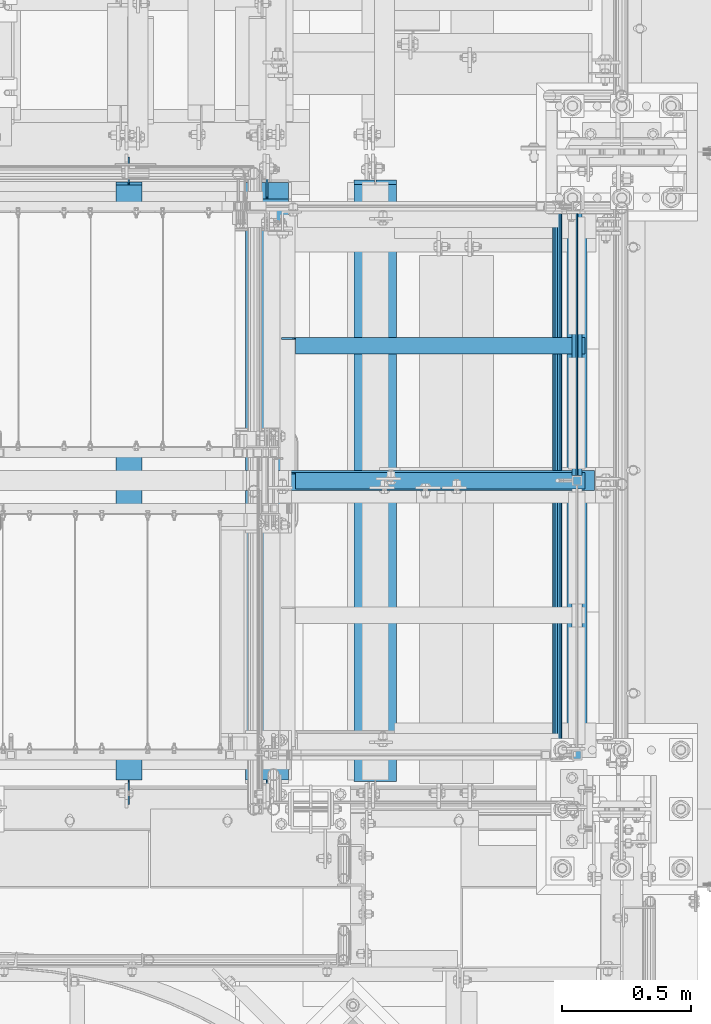
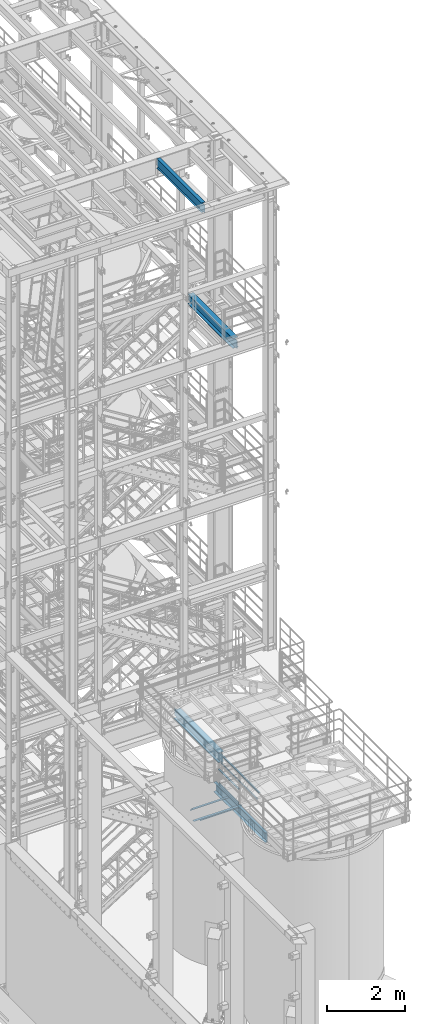
# One storey, part 985 of 1876: 11 beams, 6 elements without a shape of their own.
"""IFC2X3 building model written with IfcOpenShell, lengths in millimetres."""

from ifc_helpers import new_model, si_unit, frame, origin_with_axes, place, context, subcontext, project, spatial, faceted_brep, material, type_object, element, aggregate, save


model = new_model("IFC2X3")

# Units and contexts
model_context = context("Model", 3, precision=1e-05, world=origin_with_axes())
body_context = subcontext(model_context, "Body", "Model", "MODEL_VIEW")
ifc_project = project(units=[si_unit("LENGTHUNIT", "METRE", prefix="MILLI"), si_unit("AREAUNIT", "SQUARE_METRE"), si_unit("VOLUMEUNIT", "CUBIC_METRE"), si_unit("MASSUNIT", "GRAM", prefix="KILO"), si_unit("TIMEUNIT", "SECOND"), si_unit("PLANEANGLEUNIT", "RADIAN"), si_unit("SOLIDANGLEUNIT", "STERADIAN"), si_unit("THERMODYNAMICTEMPERATUREUNIT", "DEGREE_CELSIUS"), si_unit("LUMINOUSINTENSITYUNIT", "LUMEN")], contexts=[model_context])

# Site, building, storey
site_placement = place(None, origin_with_axes())
site = spatial("IfcSite", under=ifc_project, at=site_placement, CompositionType="ELEMENT")
building_placement = place(site_placement, origin_with_axes())
building = spatial("IfcBuilding", under=site, at=building_placement, Name="Undefined", CompositionType="ELEMENT")
storey_placement = place(building_placement, origin_with_axes())
storey = spatial("IfcBuildingStorey", under=building, at=storey_placement, Name="Undefined", CompositionType="ELEMENT", Elevation=0.0)

# Assembly, beams
assembly_1_placement = place(storey_placement, origin_with_axes())
assembly_1 = element("IfcElementAssembly", 1, at=assembly_1_placement, inside=storey, Name="STRINGER", AssemblyPlace="NOTDEFINED", PredefinedType="RIGID_FRAME")
ifc_material_1 = material(Name="STEEL/A36")
beam_type_1 = type_object("IfcBeamType", Name="L2-1/2X2-1/2X1/4", PredefinedType="NOTDEFINED")
beam_1_placement = place(assembly_1_placement, frame((6299.20000020042, -5842.00000113825, 2266.27941839083), z_axis=(0.0, -1.0, 0.0), x_axis=(1.0, 0.0, 0.0)))
beam_1 = element("IfcBeam", 2, at=beam_1_placement, type_object=beam_type_1, material=ifc_material_1, Name="STRINGER", ObjectType="L2-1/2X2-1/2X1/4", context=body_context, shape_type="Brep", body=[
    faceted_brep([(1177.92499923677, 25.4000000000001, -25.3999999999996), (1177.92499923677, 25.4000000000001, 31.75), (58.737000000001, 25.4000000000001, 31.75), (58.737000000001, 25.4000000000001, -25.3999999999996), (1177.92499923677, 31.75, 31.75), (58.737000000001, 31.75, 31.75), (46.0370001907359, 6.34999909337057, -25.3999999999996), (46.0370001907359, 6.34999909337057, -31.75), (6.34999514770607, 6.34999909337057, -31.75), (6.34999514770607, 6.34999909337057, -25.3999999999996), (50.8970797087813, 7.31672901595857, -25.3999999999996), (50.8970797087813, 7.31672901595857, -31.75), (55.017256176935, 10.0697429164366, -25.3999999999996), (55.017256176935, 10.0697429164366, -31.75), (57.7702700774134, 14.1899193845902, -25.3999999999996), (57.7702700774134, 14.1899193845902, -31.75), (58.737000000001, 19.0499989026357, -25.3999999999996), (58.737000000001, 19.0499989026357, -31.75), (58.737000000001, 31.75, -31.75), (1177.92499923677, 31.75, -31.75), (1177.92499923677, -31.75, -25.3999999999996), (1177.92499923677, -31.75, -31.75), (6.34999999999854, -31.75, -25.3999999999996), (6.34999999999854, -31.75, -31.75), (6.34999514770607, -19.0499986178111, -31.75), (6.34999514770607, -19.0499986178111, -25.3999999999996)], [[[0, 1, 2, 3]], [[1, 4, 5, 2]], [[6, 7, 8, 9]], [[10, 11, 7, 6]], [[12, 13, 11, 10]], [[14, 15, 13, 12]], [[16, 17, 15, 14]], [[2, 5, 18, 17, 16, 3]], [[4, 19, 18, 5]], [[1, 0, 20, 21, 19, 4]], [[21, 20, 22, 23]], [[8, 7, 11, 13, 15, 17, 18, 19, 21, 23, 24]], [[9, 8, 24, 25]], [[20, 0, 3, 16, 14, 12, 10, 6, 9, 25, 22]], [[24, 23, 22, 25]]]),
])
beam_2_placement = place(assembly_1_placement, frame((6299.20000038161, -5321.30000113914, 2266.27941824714), z_axis=(0.0, -1.0, 0.0), x_axis=(1.0, 0.0, 0.0)))
beam_2 = element("IfcBeam", 3, at=beam_2_placement, type_object=beam_type_1, material=ifc_material_1, Name="STRINGER", ObjectType="L2-1/2X2-1/2X1/4", context=body_context, shape_type="Brep", body=[
    faceted_brep([(1177.92499923677, 25.4000000000001, -25.3999999999996), (1177.92499923677, 25.4000000000001, 31.75), (58.737000000001, 25.4000000000001, 31.75), (58.737000000001, 25.4000000000001, -25.3999999999996), (1177.92499923677, 31.75, 31.75), (58.737000000001, 31.75, 31.75), (46.0370001907359, 6.34999909337057, -25.3999999999996), (46.0370001907359, 6.34999909337057, -31.75), (6.34999514770607, 6.34999909337057, -31.75), (6.34999514770607, 6.34999909337057, -25.3999999999996), (50.8970797087813, 7.31672901595857, -25.3999999999996), (50.8970797087813, 7.31672901595857, -31.75), (55.017256176935, 10.0697429164366, -25.3999999999996), (55.017256176935, 10.0697429164366, -31.75), (57.7702700774134, 14.1899193845902, -25.3999999999996), (57.7702700774134, 14.1899193845902, -31.75), (58.737000000001, 19.0499989026357, -25.3999999999996), (58.737000000001, 19.0499989026357, -31.75), (58.737000000001, 31.75, -31.75), (1177.92499923677, 31.75, -31.75), (1177.92499923677, -31.75, -25.3999999999996), (1177.92499923677, -31.75, -31.75), (6.34999999999854, -31.75, -25.3999999999996), (6.34999999999854, -31.75, -31.75), (6.34999514770607, -19.0499986178111, -31.75), (6.34999514770607, -19.0499986178111, -25.3999999999996)], [[[0, 1, 2, 3]], [[1, 4, 5, 2]], [[6, 7, 8, 9]], [[10, 11, 7, 6]], [[12, 13, 11, 10]], [[14, 15, 13, 12]], [[16, 17, 15, 14]], [[2, 5, 18, 17, 16, 3]], [[4, 19, 18, 5]], [[1, 0, 20, 21, 19, 4]], [[21, 20, 22, 23]], [[8, 7, 11, 13, 15, 17, 18, 19, 21, 23, 24]], [[9, 8, 24, 25]], [[20, 0, 3, 16, 14, 12, 10, 6, 9, 25, 22]], [[24, 23, 22, 25]]]),
])

# Assembly, beam
assembly_2_placement = place(storey_placement, origin_with_axes())
assembly_2 = element("IfcElementAssembly", 4, at=assembly_2_placement, inside=storey, Name="RAIL", AssemblyPlace="NOTDEFINED", PredefinedType="RIGID_FRAME")
beam_type_2 = type_object("IfcBeamType", PredefinedType="NOTDEFINED")
beam_3_placement = place(assembly_2_placement, frame((7446.96249979876, -4800.6000004494, 2393.27941810157), z_axis=(0.0, 0.0, 1.0), x_axis=(0.0, -1.0, 0.0)))
beam_3 = element("IfcBeam", 5, at=beam_3_placement, type_object=beam_type_2, material=ifc_material_1, Name="PLATE", context=body_context, shape_type="Brep", body=[
    faceted_brep([(0.0, 3.17500000000018, -50.8000000000002), (0.0, 3.17500000000018, 50.8000000000002), (1022.35000148923, 3.17500000000018, 50.8000000000002), (1022.35000148923, 3.17500000000018, -50.8000000000002), (0.0, -3.17500000000018, 50.8000000000002), (1022.35000148923, -3.17500000000018, 50.8000000000002), (0.0, -3.17500000000018, -50.8000000000002), (1022.35000148923, -3.17500000000018, -50.8000000000002)], [[[0, 1, 2, 3]], [[1, 4, 5, 2]], [[4, 6, 7, 5]], [[6, 0, 3, 7]], [[5, 7, 3, 2]], [[6, 4, 1, 0]]]),
])

assembly_3_placement = place(storey_placement, origin_with_axes())
assembly_3 = element("IfcElementAssembly", 6, at=assembly_3_placement, inside=storey, Name="BEAM", AssemblyPlace="NOTDEFINED", PredefinedType="RIGID_FRAME")
ifc_material_2 = material(Name="STEEL/A992")
beam_type_3 = type_object("IfcBeamType", Name="W12X16", PredefinedType="NOTDEFINED")
beam_4_placement = place(assembly_3_placement, frame((5715.0, -7112.0, 22402.8), z_axis=(0.0, 0.0, 1.0), x_axis=(0.0, 1.0, 0.0)))
beam_4 = element("IfcBeam", 7, at=beam_4_placement, type_object=beam_type_3, material=ifc_material_2, Name="BEAM", ObjectType="W12X16", context=body_context, shape_type="Brep", body=[
    faceted_brep([(17.4625000000005, -3.17500000000018, -126.999999999999), (17.4625000000005, 3.17500000000018, -126.999999999999), (100.012500190734, 3.17500000000018, -126.999999999999), (100.012500190734, -3.17500000000018, -126.999999999999), (104.87257970878, 3.17500000000018, -127.966729922587), (104.87257970878, -3.17500000000018, -127.966729922587), (108.992756176934, 3.17500000000018, -130.719743823065), (108.992756176934, -3.17500000000018, -130.719743823065), (111.745770077412, 3.17500000000018, -134.839920291219), (111.745770077412, -3.17500000000018, -134.839920291219), (112.7125, -3.17500000000018, -139.699999809264), (112.7125, 3.17500000000018, -139.699999809264), (112.712500000001, 3.17500000000018, -146.049999999999), (112.7125, 50.8000000000002, -146.05), (112.7125, 50.8000000000002, -152.4), (112.7125, -50.8000000000002, -152.4), (112.7125, -50.8000000000002, -146.05), (112.712500000001, -3.17500000000018, -146.049999999999), (2412.20625, 50.8000000000002, 146.049999999999), (2412.20625, 3.17500000000018, 146.049999999999), (112.712500000001, 3.17500000000018, 146.05), (112.712500000001, 50.8000000000002, 146.049999999999), (100.012500190735, -3.17500000000018, 114.299999999996), (100.012500190735, 3.17500000000018, 114.299999999996), (17.4624999999996, 3.17500000000018, 114.299999999996), (17.4624999999996, -3.17500000000018, 114.299999999996), (104.872579708781, -3.17500000000018, 115.266729922583), (104.872579708781, 3.17500000000018, 115.266729922583), (108.992756176935, -3.17500000000018, 118.019743823061), (108.992756176935, 3.17500000000018, 118.019743823061), (111.745770077413, -3.17500000000018, 122.139920291214), (111.745770077413, 3.17500000000018, 122.139920291214), (112.712500000001, -3.17500000000018, 126.999999809261), (112.712500000001, 3.17500000000018, 126.999999809261), (2412.20625, -50.8000000000002, 152.400000000001), (2412.20625, 50.8000000000002, 152.400000000001), (112.712500000001, 50.8000000000002, 152.400000000001), (112.712500000001, -50.8000000000002, 152.400000000001), (2412.20625, -50.8000000000002, 146.049999999999), (112.712500000001, -50.8000000000002, 146.049999999999), (2412.20625, -3.17500000000018, 146.049999999999), (112.712500000001, -3.17500000000018, 146.05), (2412.20625, -3.17500000000018, 126.999999809268), (2412.20625, 3.17500000000018, 126.999999809268), (2413.17297992259, -3.17500000000018, 122.139920291222), (2413.17297992259, 3.17500000000018, 122.139920291222), (2415.92599382307, -3.17500000000018, 118.019743823068), (2415.92599382307, 3.17500000000018, 118.019743823068), (2420.04617029122, -3.17500000000018, 115.26672992259), (2420.04617029122, 3.17500000000018, 115.26672992259), (2424.90624980927, -3.17500000000018, 114.300000000003), (2424.90624980927, 3.17500000000018, 114.300000000003), (2520.15625, -3.17500000000018, 114.300000000003), (2520.15625, 3.17500000000018, 114.300000000003), (2520.15625, -3.17500000000018, -126.999999999996), (2520.15625, 3.17500000000018, -126.999999999996), (2437.60624980927, -3.17500000000018, -126.999999999996), (2437.60624980927, 3.17500000000018, -126.999999999996), (2432.74617029122, -3.17500000000018, -127.966729922584), (2432.74617029122, 3.17500000000018, -127.966729922584), (2428.62599382307, -3.17500000000018, -130.719743823061), (2428.62599382307, 3.17500000000018, -130.719743823061), (2425.87297992259, -3.17500000000018, -134.839920291215), (2425.87297992259, 3.17500000000018, -134.839920291215), (2424.90625, -3.17500000000018, -139.699999809261), (2424.90625, 3.17500000000018, -139.699999809261), (2424.90625, -3.17500000000018, -146.049999999999), (2424.90625, -50.8000000000002, -146.049999999999), (2424.90625, -50.8000000000002, -152.400000000001), (2424.90625, 50.8000000000002, -152.400000000001), (2424.90625, 50.8000000000002, -146.049999999999), (2424.90625, 3.17500000000018, -146.049999999999)], [[[0, 1, 2, 3]], [[3, 2, 4, 5]], [[5, 4, 6, 7]], [[7, 6, 8, 9]], [[10, 11, 12, 13, 14, 15, 16, 17]], [[9, 8, 11, 10]], [[18, 19, 20, 21]], [[22, 23, 24, 25]], [[26, 27, 23, 22]], [[28, 29, 27, 26]], [[30, 31, 29, 28]], [[32, 33, 31, 30]], [[34, 35, 36, 37]], [[38, 34, 37, 39]], [[40, 38, 39, 41]], [[37, 36, 21, 20, 33, 32, 41, 39]], [[35, 18, 21, 36]], [[34, 38, 40, 42, 43, 19, 18, 35]], [[44, 45, 43, 42]], [[46, 47, 45, 44]], [[48, 49, 47, 46]], [[50, 51, 49, 48]], [[52, 53, 51, 50]], [[53, 52, 54, 55]], [[54, 56, 57, 55]], [[58, 59, 57, 56]], [[60, 61, 59, 58]], [[62, 63, 61, 60]], [[64, 65, 63, 62]], [[66, 67, 68, 69, 70, 71, 65, 64]], [[67, 66, 17, 16]], [[68, 67, 16, 15]], [[69, 68, 15, 14]], [[70, 69, 14, 13]], [[71, 70, 13, 12]], [[6, 4, 2, 1, 24, 23, 27, 29, 31, 33, 20, 19, 43, 45, 47, 49, 51, 53, 55, 57, 59, 61, 63, 65, 71, 12, 11, 8]], [[25, 24, 1, 0]], [[66, 64, 62, 60, 58, 56, 54, 52, 50, 48, 46, 44, 42, 40, 41, 32, 30, 28, 26, 22, 25, 0, 3, 5, 7, 9, 10, 17]]]),
])
aggregate(assembly_3, [beam_4])

# Beam
ifc_material_3 = material()
beam_type_4 = type_object("IfcBeamType", Name="HSS1-1/2X1-1/2X1/8", PredefinedType="NOTDEFINED")
beam_5_placement = place(assembly_2_placement, frame((7446.9625, -5842.00000117362, 2838.45), z_axis=(0.0, 0.0, 1.0), x_axis=(0.0, 1.0, 0.0)))
beam_5 = element("IfcBeam", 8, at=beam_5_placement, type_object=beam_type_4, material=ifc_material_3, Name="RAIL", ObjectType="HSS1-1/2X1-1/2X1/8", context=body_context, shape_type="Brep", body=[
    faceted_brep([(19.0500000000002, -19.0499992349996, 19.0499992350001), (19.0500000000002, 19.0499992349996, 19.0499992350001), (19.0500000000002, 19.0499992349996, -19.0499992350001), (19.0500000000002, -19.0499992349996, -19.0499992350001), (19.0500000000002, -15.8749992829999, 15.8749992829999), (19.0500000000002, -15.8749992829999, -15.8749992829999), (19.0500000000002, 15.8749992829999, -15.8749992829999), (19.0500000000002, 15.8749992829999, 15.8749992829999), (1041.40000072423, 19.0499992349996, -19.0499992350001), (1041.40000072423, -19.0499992349996, -19.0499992350001), (1041.40000072423, -19.0499992349996, 19.0499992350001), (1041.40000072423, 19.0499992349996, 19.0499992350001), (1041.40000072423, -15.8749992829999, 15.8749992829999), (1041.40000072423, 15.8749992829999, 15.8749992829999), (1041.40000072423, 15.8749992829999, -15.8749992829999), (1041.40000072423, -15.8749992829999, -15.8749992829999)], [[[0, 1, 2, 3], [4, 5, 6, 7]], [[8, 9, 3, 2]], [[9, 10, 0, 3]], [[10, 11, 1, 0]], [[11, 8, 2, 1]], [[10, 9, 8, 11], [12, 13, 14, 15]], [[13, 12, 4, 7]], [[14, 13, 7, 6]], [[15, 14, 6, 5]], [[12, 15, 5, 4]]]),
])

beam_6_placement = place(assembly_2_placement, frame((7446.9625, -4762.5000019794, 3371.85), z_axis=(0.0, 0.0, -1.0), x_axis=(0.0, -1.0, 0.0)))
beam_6 = element("IfcBeam", 9, at=beam_6_placement, type_object=beam_type_4, material=ifc_material_3, Name="RAIL", ObjectType="HSS1-1/2X1-1/2X1/8", context=body_context, shape_type="Brep", body=[
    faceted_brep([(3.17499995199978, 15.8749992829999, -15.8749992829999), (3.17499995199978, -15.8749992829999, -15.8749992829999), (2155.82499843646, -15.8749992829999, -15.8749992829999), (2155.82499843646, 15.8749992829999, -15.8749992829999), (34.9249985179995, -15.8749992829999, 15.8749992829999), (2124.07499987046, -15.8749992829999, 15.8749992829999), (34.9249985179995, 15.8749992829999, 15.8749992829999), (2124.07499987046, 15.8749992829999, 15.8749992829999), (0.0, 19.0499992349996, -19.0499992350001), (38.0999984699993, 19.0499992349996, 19.0499992350001), (2120.89999991846, 19.0499992349996, 19.0499992350001), (2158.99999838846, 19.0499992349996, -19.0499992350001), (38.0999984699993, -19.0499992349996, 19.0499992350001), (2120.89999991846, -19.0499992349996, 19.0499992350001), (0.0, -19.0499992349996, -19.0499992350001), (2158.99999838846, -19.0499992349996, -19.0499992350001)], [[[0, 1, 2, 3]], [[1, 4, 5, 2]], [[4, 6, 7, 5]], [[6, 0, 3, 7]], [[8, 9, 10, 11]], [[9, 12, 13, 10]], [[12, 14, 15, 13]], [[14, 8, 11, 15]], [[13, 15, 11, 10], [5, 7, 3, 2]], [[14, 12, 9, 8], [6, 4, 1, 0]]]),
])

beam_type_5 = type_object("IfcBeamType", Name="C12X20.7", PredefinedType="NOTDEFINED")
beam_7_placement = place(assembly_1_placement, frame((7446.9625, -7242.175, 2178.05), z_axis=(0.0, 0.0, -1.0), x_axis=(0.0, 1.0, 0.0)))
beam_7 = element("IfcBeam", 10, at=beam_7_placement, type_object=beam_type_5, material=ifc_material_1, Name="STRINGER", ObjectType="C12X20.7", context=body_context, shape_type="Brep", body=[
    faceted_brep([(0.0, 38.1000000000004, -152.4), (0.0, 38.1000000000004, 152.4), (2645.5687500029, 38.1000000000004, 152.4), (2645.5687500029, 38.1000000000004, -152.4), (0.0, -38.1000000000004, 152.4), (2645.5687500029, -38.1000000000004, 152.4), (0.0, -38.1000000000004, 146.04746), (2645.5687500029, -38.1000000000004, 146.04746), (0.0, 30.1625000000004, 134.6749275), (2645.5687500029, 30.1625000000004, 134.6749275), (0.0, 30.1625000000004, -134.6749275), (2645.5687500029, 30.1625000000004, -134.6749275), (0.0, -38.1000000000004, -146.04746), (2645.5687500029, -38.1000000000004, -146.04746), (0.0, -38.1000000000004, -152.4), (2645.5687500029, -38.1000000000004, -152.4)], [[[0, 1, 2, 3]], [[1, 4, 5, 2]], [[4, 6, 7, 5]], [[6, 8, 9, 7]], [[8, 10, 11, 9]], [[10, 12, 13, 11]], [[12, 14, 15, 13]], [[14, 0, 3, 15]], [[5, 7, 9, 11, 13, 15, 3, 2]], [[14, 12, 10, 8, 6, 4, 1, 0]]]),
])

aggregate(assembly_1, [beam_7, beam_1, beam_2])

beam_type_6 = type_object("IfcBeamType", PredefinedType="NOTDEFINED")
beam_8_placement = place(assembly_2_placement, frame((7370.76250000001, -4806.95002479037, 3218.68417159045), z_axis=(0.0, 0.0, 1.0), x_axis=(0.0, -1.0, 0.0)))
beam_8 = element("IfcBeam", 11, at=beam_8_placement, type_object=beam_type_6, material=ifc_material_3, context=body_context, shape_type="Brep", body=[
    faceted_brep([(-38.0999999999985, -15.875, 0.0), (-38.0999999999985, -13.7481532850779, 7.9375), (2108.19997558594, -13.7481532850779, 7.9375), (2108.19997558594, -15.875, 0.0), (-38.0999999999985, -7.9375, 13.7481532850779), (2108.19997558594, -7.9375, 13.7481532850779), (-38.0999999999985, 0.0, 15.875), (2108.19997558594, 0.0, 15.875), (-38.0999999999985, 7.9375, 13.7481532850779), (2108.19997558594, 7.9375, 13.7481532850779), (-38.0999999999985, 13.7481532850779, 7.9375), (2108.19997558594, 13.7481532850779, 7.9375), (-38.0999999999985, 15.875, 0.0), (2108.19997558594, 15.875, 0.0), (-38.0999999999985, 13.7481532850779, -7.9375), (2108.19997558594, 13.7481532850779, -7.9375), (-38.0999999999985, 7.9375, -13.7481532850779), (2108.19997558594, 7.9375, -13.7481532850779), (-38.0999999999985, 0.0, -15.875), (2108.19997558594, 0.0, -15.875), (-38.0999999999985, -7.9375, -13.7481532850779), (2108.19997558594, -7.9375, -13.7481532850779), (-38.0999999999985, -13.7481532850779, -7.9375), (2108.19997558594, -13.7481532850779, -7.9375), (-38.0999999999985, -19.0500000000002, 0.0), (-38.0999999999985, -16.4977839420935, -9.52500000000009), (2108.19997558594, -16.4977839420935, -9.52500000000009), (2108.19997558594, -19.0500000000002, 0.0), (-38.0999999999985, -9.52499999999964, -16.4977839420935), (2108.19997558594, -9.52499999999964, -16.4977839420935), (-38.0999999999985, 0.0, -19.0500000000002), (2108.19997558594, 0.0, -19.0500000000002), (-38.0999999999985, 9.52499999999964, -16.4977839420935), (2108.19997558594, 9.52499999999964, -16.4977839420935), (-38.0999999999985, 16.4977839420935, -9.52500000000009), (2108.19997558594, 16.4977839420935, -9.52500000000009), (-38.0999999999985, 19.0500000000002, 0.0), (2108.19997558594, 19.0500000000002, 0.0), (-38.0999999999985, 16.4977839420935, 9.52500000000009), (2108.19997558594, 16.4977839420935, 9.52500000000009), (-38.0999999999985, 9.52499999999964, 16.4977839420935), (2108.19997558594, 9.52499999999964, 16.4977839420935), (-38.0999999999985, 0.0, 19.0500000000002), (2108.19997558594, 0.0, 19.0500000000002), (-38.0999999999985, -9.52499999999964, 16.4977839420935), (2108.19997558594, -9.52499999999964, 16.4977839420935), (-38.0999999999985, -16.4977839420935, 9.52500000000009), (2108.19997558594, -16.4977839420935, 9.52500000000009)], [[[0, 1, 2, 3]], [[1, 4, 5, 2]], [[4, 6, 7, 5]], [[6, 8, 9, 7]], [[8, 10, 11, 9]], [[10, 12, 13, 11]], [[12, 14, 15, 13]], [[14, 16, 17, 15]], [[16, 18, 19, 17]], [[18, 20, 21, 19]], [[20, 22, 23, 21]], [[22, 0, 3, 23]], [[24, 25, 26, 27]], [[25, 28, 29, 26]], [[28, 30, 31, 29]], [[30, 32, 33, 31]], [[32, 34, 35, 33]], [[34, 36, 37, 35]], [[36, 38, 39, 37]], [[38, 40, 41, 39]], [[40, 42, 43, 41]], [[42, 44, 45, 43]], [[44, 46, 47, 45]], [[46, 24, 27, 47]], [[29, 31, 33, 35, 37, 39, 41, 43, 45, 47, 27, 26], [5, 7, 9, 11, 13, 15, 17, 19, 21, 23, 3, 2]], [[46, 44, 42, 40, 38, 36, 34, 32, 30, 28, 25, 24], [22, 20, 18, 16, 14, 12, 10, 8, 6, 4, 1, 0]]]),
])

aggregate(assembly_2, [beam_5, beam_6, beam_8, beam_3])

# Assembly, beam
assembly_4_placement = place(storey_placement, origin_with_axes())
assembly_4 = element("IfcElementAssembly", 12, at=assembly_4_placement, inside=storey, Name="ref.", AssemblyPlace="NOTDEFINED", PredefinedType="RIGID_FRAME")
ifc_material_4 = material(Name="STEEL/Steel_Undefined")
beam_type_7 = type_object("IfcBeamType", PredefinedType="NOTDEFINED")
beam_9_placement = place(assembly_4_placement, frame((6088.62272832936, -5842.00000113818, 2326.50862061127), z_axis=(0.0, -1.0, 0.0), x_axis=(1.0, 0.0, 0.0)))
beam_9 = element("IfcBeam", 13, at=beam_9_placement, type_object=beam_type_7, material=ifc_material_4, Name="ref.", context=body_context, shape_type="Brep", body=[
    faceted_brep([(0.0, 3.17500000000018, -38.1000000000004), (0.0, 3.17500000000018, 38.1000000000004), (1426.59072456575, 3.17500000000018, 38.1000000000004), (1426.59072456575, 3.17500000000018, -38.1000000000004), (0.0, -3.17500000000018, 38.1000000000004), (1426.59072456575, -3.17500000000018, 38.1000000000004), (0.0, -3.17500000000018, -38.1000000000004), (1426.59072456575, -3.17500000000018, -38.1000000000004)], [[[0, 1, 2, 3]], [[1, 4, 5, 2]], [[4, 6, 7, 5]], [[6, 0, 3, 7]], [[5, 7, 3, 2]], [[6, 4, 1, 0]]]),
])
aggregate(assembly_4, [beam_9])

assembly_5_placement = place(storey_placement, origin_with_axes())
assembly_5 = element("IfcElementAssembly", 14, at=assembly_5_placement, inside=storey, Name="BEAM", AssemblyPlace="NOTDEFINED", PredefinedType="RIGID_FRAME")
beam_type_8 = type_object("IfcBeamType", Name="W12X30", PredefinedType="NOTDEFINED")
beam_10_placement = place(assembly_5_placement, frame((6667.5, -7112.0, 17826.0375), z_axis=(0.0, 0.0, 1.0), x_axis=(0.0, 1.0, 0.0)))
beam_10 = element("IfcBeam", 15, at=beam_10_placement, type_object=beam_type_8, material=ifc_material_2, Name="BEAM", ObjectType="W12X30", context=body_context, shape_type="Brep", body=[
    faceted_brep([(17.4624999999996, -3.17500000000018, -131.762500000004), (17.4624999999996, 3.17500000000018, -131.762500000004), (93.6625001907341, 3.17500002465476, -131.762500000004), (93.6625001907341, -3.17500000000018, -131.762500000004), (98.5225797087796, 3.1750000248112, -132.729229922592), (98.5225797087796, -3.17500000000018, -132.729229922592), (102.642756176933, 3.17500002525321, -135.482243823069), (102.642756176933, -3.17500000000018, -135.482243823069), (105.395770077412, 3.1750000259135, -139.602420291223), (105.395770077412, -3.17500000000018, -139.602420291223), (106.362499999999, -3.17500000000018, -144.46249980927), (106.362499999999, 3.17500002669112, -144.46249980927), (106.362499999999, 3.17500009484957, -146.049999999999), (106.362499999999, 82.5500000000002, -146.049999999999), (106.362499999999, 82.5500000000002, -157.162499999999), (106.362499999999, -82.5500000000002, -157.162499999999), (106.362499999999, -82.5500000000002, -146.049999999999), (106.362499999999, -3.17500000000018, -146.049999999999), (2413.79375, 82.5500000000002, 146.049999999999), (2413.79375, 3.17500000000018, 146.049999999999), (106.362499999999, 3.17500000000018, 146.049999999999), (106.362499999999, 82.5500000000002, 146.049999999999), (93.6625001907341, -3.17500000000018, 125.412499999995), (93.6625001907341, 3.17499998419134, 125.412499999995), (17.4624999999996, 3.17500000000018, 125.412499999995), (17.4624999999996, -3.17500000000018, 125.412499999995), (98.5225797087796, -3.17500000000018, 126.379229922582), (98.5225797087796, 3.17499998403764, 126.379229922582), (102.642756176933, -3.17500000000018, 129.13224382306), (102.642756176933, 3.17499998359926, 129.13224382306), (105.395770077412, -3.17500000000018, 133.252420291214), (105.395770077412, 3.17499998294261, 133.252420291214), (106.362499999999, -3.17500000000018, 138.11249980926), (106.362499999999, 3.17499998216772, 138.11249980926), (2413.79375, -82.5500000000002, 157.162499999999), (2413.79375, 82.5500000000002, 157.162499999999), (106.362499999999, 82.5500000000002, 157.162499999999), (106.362499999999, -82.5500000000002, 157.162499999999), (2413.79375, -82.5500000000002, 146.049999999999), (106.362499999999, -82.5500000000002, 146.049999999999), (2413.79375, -3.17500000000018, 146.049999999999), (106.362499999999, -3.17500000000018, 146.049999999999), (2413.79375, -3.17500000000018, 125.41249980927), (2413.79375, 3.17500000000018, 125.41249980927), (2414.76047992259, -3.17500000000018, 120.552420291224), (2414.76047992259, 3.17500000000018, 120.552420291224), (2417.51349382307, -3.17500000000018, 116.43224382307), (2417.51349382307, 3.17500000000018, 116.43224382307), (2421.63367029122, -3.17500000000018, 113.679229922593), (2421.63367029122, 3.17500000000018, 113.679229922593), (2426.49374980926, -3.17500000000018, 112.712500000005), (2426.49374980926, 3.17500000000018, 112.712500000005), (2520.15625, -3.17500000000018, 112.712500000005), (2520.15625, 3.17500000000018, 112.712500000005), (2520.15625, -3.17500000000018, -131.762499999993), (2520.15625, 3.17500000000018, -131.762499999993), (2443.95624980927, -3.17500000000018, -131.762499999993), (2443.95624980927, 3.17500000000018, -131.762499999993), (2439.09617029122, -3.17500000000018, -132.729229922581), (2439.09617029122, 3.17500000000018, -132.729229922581), (2434.97599382307, -3.17500000000018, -135.482243823059), (2434.97599382307, 3.17500000000018, -135.482243823059), (2432.22297992259, -3.17500000000018, -139.602420291212), (2432.22297992259, 3.17500000000018, -139.602420291212), (2431.25625, -3.17500000000018, -144.462499809259), (2431.25625, 3.17500000000018, -144.462499809259), (2431.25625, -3.17500000000018, -146.049999999999), (2431.25625, -82.5500000000002, -146.049999999999), (2431.25625, -82.5500000000002, -157.162499999999), (2431.25625, 82.5500000000002, -157.162499999999), (2431.25625, 82.5500000000002, -146.049999999999), (2431.25625, 3.17500000000018, -146.049999999999)], [[[0, 1, 2, 3]], [[3, 2, 4, 5]], [[5, 4, 6, 7]], [[7, 6, 8, 9]], [[10, 11, 12, 13, 14, 15, 16, 17]], [[9, 8, 11, 10]], [[18, 19, 20, 21]], [[22, 23, 24, 25]], [[26, 27, 23, 22]], [[28, 29, 27, 26]], [[30, 31, 29, 28]], [[32, 33, 31, 30]], [[34, 35, 36, 37]], [[38, 34, 37, 39]], [[40, 38, 39, 41]], [[37, 36, 21, 20, 33, 32, 41, 39]], [[35, 18, 21, 36]], [[34, 38, 40, 42, 43, 19, 18, 35]], [[44, 45, 43, 42]], [[46, 47, 45, 44]], [[48, 49, 47, 46]], [[50, 51, 49, 48]], [[52, 53, 51, 50]], [[53, 52, 54, 55]], [[54, 56, 57, 55]], [[58, 59, 57, 56]], [[60, 61, 59, 58]], [[62, 63, 61, 60]], [[64, 65, 63, 62]], [[66, 67, 68, 69, 70, 71, 65, 64]], [[67, 66, 17, 16]], [[68, 67, 16, 15]], [[69, 68, 15, 14]], [[70, 69, 14, 13]], [[71, 70, 13, 12]], [[6, 4, 2, 1, 24, 23, 27, 29, 31, 33, 20, 19, 43, 45, 47, 49, 51, 53, 55, 57, 59, 61, 63, 65, 71, 12, 11, 8]], [[25, 24, 1, 0]], [[66, 64, 62, 60, 58, 56, 54, 52, 50, 48, 46, 44, 42, 40, 41, 32, 30, 28, 26, 22, 25, 0, 3, 5, 7, 9, 10, 17]]]),
])
aggregate(assembly_5, [beam_10])

assembly_6_placement = place(storey_placement, origin_with_axes())
assembly_6 = element("IfcElementAssembly", 16, at=assembly_6_placement, inside=storey, Name="BEAM", AssemblyPlace="NOTDEFINED", PredefinedType="RIGID_FRAME")
beam_11_placement = place(assembly_6_placement, frame((6248.4, -7112.0, 4973.6375), z_axis=(0.0, 0.0, 1.0), x_axis=(0.0, 1.0, 0.0)))
beam_11 = element("IfcBeam", 17, at=beam_11_placement, type_object=beam_type_8, material=ifc_material_2, Name="BEAM", ObjectType="W12X30", context=body_context, shape_type="Brep", body=[
    faceted_brep([(17.4624999999996, -3.17500000000018, -131.762500000004), (17.4624999999996, 3.17500000000018, -131.762500000004), (100.012500190735, 3.17500000000018, -131.762500000001), (100.012500190735, -3.17500000000018, -131.762500000001), (104.872579708781, 3.17500000000018, -132.729229922588), (104.872579708781, -3.17500000000018, -132.729229922588), (108.992756176935, 3.17500000000018, -135.482243823066), (108.992756176935, -3.17500000000018, -135.482243823066), (111.745770077413, 3.17500000000018, -139.602420291219), (111.745770077413, -3.17500000000018, -139.602420291219), (112.712500000001, -3.17500000000018, -144.462499809266), (112.712500000001, 3.17500000000018, -144.462499809266), (112.712500000001, 3.17500000000018, -146.049999999999), (112.712500000001, 82.5500000000002, -146.049999999999), (112.712500000001, 82.5500000000002, -157.1625), (112.712500000001, -82.5500000000002, -157.1625), (112.712500000001, -82.5500000000002, -146.049999999999), (112.712500000001, -3.17500000000018, -146.049999999999), (2358.23125, 82.5500000000002, 146.05), (2358.23125, 3.17500000000018, 146.05), (112.712500000001, 3.17500000000018, 146.05), (112.712500000001, 82.5500000000002, 146.05), (100.012500190735, -3.17500000000018, 119.062500000001), (100.012500190735, 3.17500000000018, 119.062500000001), (17.4624999999996, 3.17500000000018, 119.0625), (17.4624999999996, -3.17500000000018, 119.0625), (104.872579708781, -3.17500000000018, 120.029229922588), (104.872579708781, 3.17500000000018, 120.029229922588), (108.992756176935, -3.17500000000018, 122.782243823067), (108.992756176935, 3.17500000000018, 122.782243823067), (111.745770077413, -3.17500000000018, 126.902420291221), (111.745770077413, 3.17500000000018, 126.902420291221), (112.712500000001, -3.17500000000018, 131.762499809266), (112.712500000001, 3.17500000000018, 131.762499809266), (2358.23125, -82.5500000000002, 157.1625), (2358.23125, 82.5500000000002, 157.1625), (112.712500000001, 82.5500000000002, 157.1625), (112.712500000001, -82.5500000000002, 157.1625), (2358.23125, -82.5500000000002, 146.05), (112.712500000001, -82.5500000000002, 146.05), (2358.23125, -3.17500000000018, 146.05), (112.712500000001, -3.17500000000018, 146.05), (2358.23125, -3.17500000000018, 119.062499809265), (2358.23125, 3.17500000000018, 119.062499809265), (2359.19797992259, -3.17500000000018, 114.20242029122), (2359.19797992259, 3.17500000000018, 114.20242029122), (2361.95099382307, -3.17500000000018, 110.082243823066), (2361.95099382307, 3.17500000000018, 110.082243823066), (2366.07117029122, -3.17500000000018, 107.329229922588), (2366.07117029122, 3.17500000000018, 107.329229922588), (2370.93124980927, -3.17500000000018, 106.3625), (2370.93124980927, 3.17500000000018, 106.3625), (2516.98125, -3.17500000000018, 106.3625), (2516.98125, 3.17500000000018, 106.3625), (2516.98125, -3.17500000000018, -131.7625), (2516.98125, 3.17500000000018, -131.7625), (2434.43124980927, -3.17500000000018, -131.7625), (2434.43124980927, 3.17500000000018, -131.7625), (2429.57117029122, -3.17500000000018, -132.729229922587), (2429.57117029122, 3.17500000000018, -132.729229922587), (2425.45099382307, -3.17500000000018, -135.482243823066), (2425.45099382307, 3.17500000000018, -135.482243823066), (2422.69797992259, -3.17500000000018, -139.602420291219), (2422.69797992259, 3.17500000000018, -139.602420291219), (2421.73125, -3.17500000000018, -144.462499809265), (2421.73125, 3.17500000000018, -144.462499809265), (2421.73125, -3.17500000000018, -146.05), (2421.73125, -82.5500000000002, -146.05), (2421.73125, -82.5500000000002, -157.1625), (2421.73125, 82.5500000000002, -157.1625), (2421.73125, 82.5500000000002, -146.05), (2421.73125, 3.17500000000018, -146.05)], [[[0, 1, 2, 3]], [[3, 2, 4, 5]], [[5, 4, 6, 7]], [[7, 6, 8, 9]], [[10, 11, 12, 13, 14, 15, 16, 17]], [[9, 8, 11, 10]], [[18, 19, 20, 21]], [[22, 23, 24, 25]], [[26, 27, 23, 22]], [[28, 29, 27, 26]], [[30, 31, 29, 28]], [[32, 33, 31, 30]], [[34, 35, 36, 37]], [[38, 34, 37, 39]], [[40, 38, 39, 41]], [[37, 36, 21, 20, 33, 32, 41, 39]], [[35, 18, 21, 36]], [[34, 38, 40, 42, 43, 19, 18, 35]], [[44, 45, 43, 42]], [[46, 47, 45, 44]], [[48, 49, 47, 46]], [[50, 51, 49, 48]], [[52, 53, 51, 50]], [[53, 52, 54, 55]], [[54, 56, 57, 55]], [[58, 59, 57, 56]], [[60, 61, 59, 58]], [[62, 63, 61, 60]], [[64, 65, 63, 62]], [[66, 67, 68, 69, 70, 71, 65, 64]], [[67, 66, 17, 16]], [[68, 67, 16, 15]], [[69, 68, 15, 14]], [[70, 69, 14, 13]], [[71, 70, 13, 12]], [[6, 4, 2, 1, 24, 23, 27, 29, 31, 33, 20, 19, 43, 45, 47, 49, 51, 53, 55, 57, 59, 61, 63, 65, 71, 12, 11, 8]], [[25, 24, 1, 0]], [[66, 64, 62, 60, 58, 56, 54, 52, 50, 48, 46, 44, 42, 40, 41, 32, 30, 28, 26, 22, 25, 0, 3, 5, 7, 9, 10, 17]]]),
])
aggregate(assembly_6, [beam_11])

save(model, "model.ifc")
